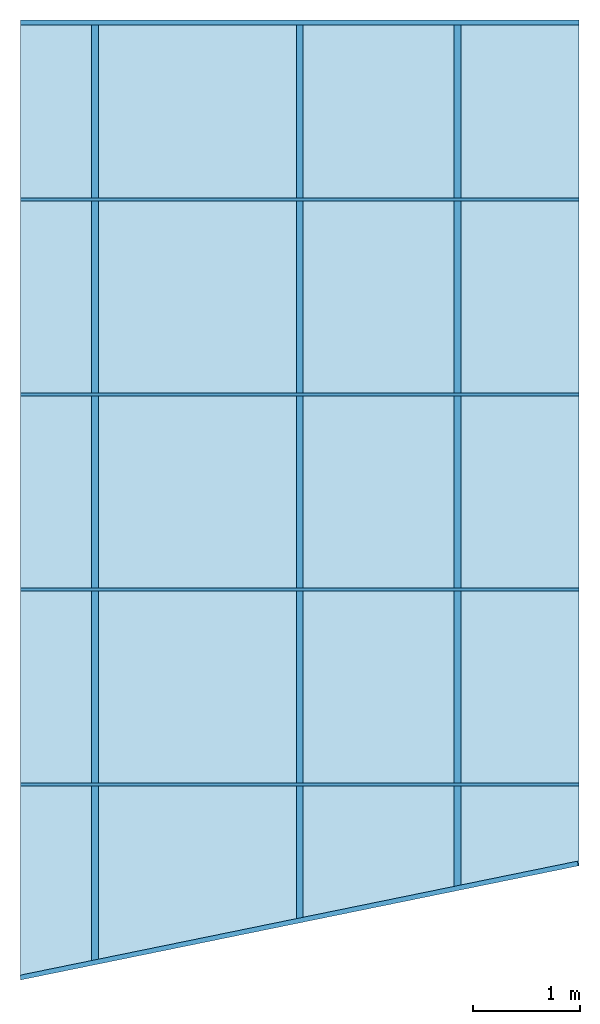
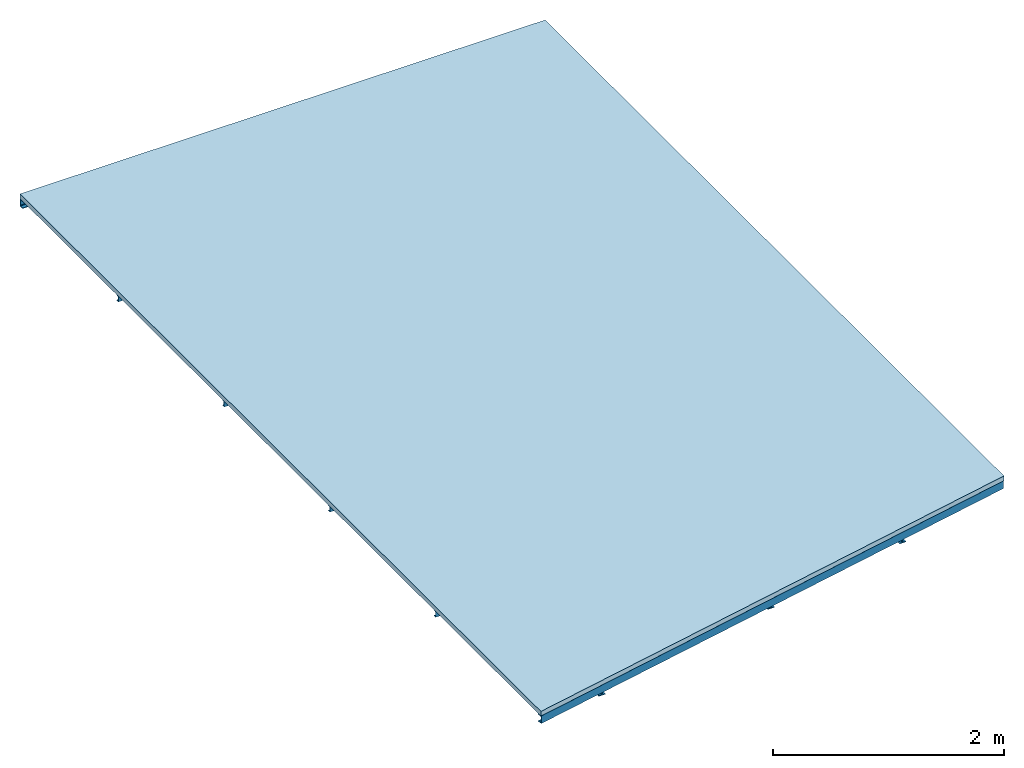
# One storey: 9 beams, 1 slab, 2 elements without a shape of their own.
"""IFC2X3 building model written with IfcOpenShell, lengths in metres."""

from ifc_helpers import new_model, entity, si_unit, converted_unit, derived_unit, direction, frame, frame_2d, origin, place, context, subcontext, project, spatial, polyline, circle_curve, parameter, trimmed, segment, composite_curve, i_section, outline, extrude, material, layer, layer_set, type_object, element, aggregate, save


model = new_model("IFC2X3")

# Units and contexts
model_context = context("Model", 3, precision=1e-05, world=origin(), true_north=direction((6.123233995736766e-17, 1.0)))
body_context = subcontext(model_context, "Body", "Model", "MODEL_VIEW")
ifc_project = project(units=[si_unit("LENGTHUNIT", "METRE"), converted_unit("PLANEANGLEUNIT", "DEGREE", entity("IfcPlaneAngleMeasure", 0.017453292519943278), si_unit("PLANEANGLEUNIT", "RADIAN"), dimensions=[0, 0, 0, 0, 0, 0, 0]), si_unit("AREAUNIT", "SQUARE_METRE"), derived_unit("THERMALTRANSMITTANCEUNIT", [(si_unit("MASSUNIT", "GRAM", prefix="KILO"), 1), (si_unit("THERMODYNAMICTEMPERATUREUNIT", "KELVIN"), -1), (si_unit("TIMEUNIT", "SECOND"), -3)])], contexts=[model_context])

# Site, building, storey
site_placement = place(None, origin())
site = spatial("IfcSite", under=ifc_project, at=site_placement, CompositionType="ELEMENT")
building_placement = place(site_placement, origin())
building = spatial("IfcBuilding", under=site, at=building_placement, CompositionType="ELEMENT")
storey_placement = place(building_placement, frame((0.0, 0.0, 7.0)))
storey = spatial("IfcBuildingStorey", under=building, at=storey_placement, Name="1", CompositionType="ELEMENT", Elevation=6.999999999999999)

# Beams
ifc_material_1 = material(Name="Metal - Steel - 345 MPa")
beam_type_1 = type_object("IfcBeamType", Name="U-Channels:UPN80", PredefinedType="BEAM")
beam_1_placement = place(storey_placement, frame((-0.390396386376727, -3.9843421885533314, 0.0), z_axis=(0.0, 0.0, 1.0), x_axis=(0.9797045907005694, 0.20044678835099888, 0.0)))
element("IfcBeam", 1, at=beam_1_placement, inside=storey, type_object=beam_type_1, material=ifc_material_1, Name="U-Channels:UPN80", ObjectType="U-Channels:UPN80", context=body_context, shape_type="SweptSolid", body=[
    extrude(outline(composite_curve([segment(polyline([(-0.039999999999997406, -0.025113503185145037), (0.04000000000000282, -0.025113503185145037)]), True, "CONTINUOUS"), segment(polyline([(0.040000000000001736, -0.025113503185145037), (0.040000000000001736, 0.019886496814854476)]), True, "CONTINUOUS"), segment(polyline([(0.040000000000001736, 0.019886496814854476), (0.03749277958527237, 0.019886496814854476)]), True, "CONTINUOUS"), segment(trimmed(circle_curve(frame_2d((0.03749277958527237, 0.015886496814854306), x_axis=(0.0, 1.0)), 0.003999999999999967), [parameter(0.0)], [parameter(85.42607874010008)], True, "PARAMETER"), True, "CONTINUOUS"), segment(polyline([(0.03350551847112868, 0.016205477703986036), (0.03126896305773739, -0.011751464963408436)]), True, "CONTINUOUS"), segment(trimmed(circle_curve(frame_2d((0.023294440829447864, -0.01111350318514497), x_axis=(0.9968152785361264, -0.07974522228287521)), 0.007999999999999823), [parameter(274.5739212598999)], [parameter(0.0)], True, "PARAMETER"), False, "CONTINUOUS"), segment(polyline([(0.023294440829447864, -0.01911350318514478), (-0.023294440829452197, -0.01911350318514532)]), True, "CONTINUOUS"), segment(trimmed(circle_curve(frame_2d((-0.023294440829452197, -0.01111350318514443), x_axis=(0.0, -1.0)), 0.008000000000000307), [parameter(274.5739212599038)], [parameter(0.0)], True, "PARAMETER"), False, "CONTINUOUS"), segment(polyline([(-0.03126896305774064, -0.011751464963408436), (-0.03350551847113194, 0.016205477703985494)]), True, "CONTINUOUS"), segment(trimmed(circle_curve(frame_2d((-0.037492779585276706, 0.015886496814854306), x_axis=(0.9968152785361264, 0.07974522228287521)), 0.0039999999999999715), [parameter(0.0)], [parameter(85.42607874010008)], True, "PARAMETER"), True, "CONTINUOUS"), segment(polyline([(-0.037492779585276706, 0.019886496814854476), (-0.039999999999997406, 0.019886496814854476)]), True, "CONTINUOUS"), segment(polyline([(-0.039999999999997406, 0.019886496814854476), (-0.039999999999997406, -0.025113503185145578)]), True, "CONTINUOUS")], self_intersect=False)), frame((0.0012111124129427226, 0.025113503185144496, -0.03999999999999632), z_axis=(1.0, 0.0, 0.0), x_axis=(0.0, 0.0, -1.0)), (0.0, 0.0, 1.0), 5.336763374453148),
])
beam_2_placement = place(storey_placement, frame((-0.3933028648078022, 5.0201700933658255, 0.0)))
element("IfcBeam", 2, at=beam_2_placement, inside=storey, type_object=beam_type_1, material=ifc_material_1, Name="U-Channels:UPN80", ObjectType="U-Channels:UPN80", context=body_context, shape_type="SweptSolid", body=[
    extrude(outline(composite_curve([segment(polyline([(-0.04000000000000282, -0.019886496814854476), (-0.03749277958527345, -0.019886496814854476)]), True, "CONTINUOUS"), segment(trimmed(circle_curve(frame_2d((-0.03749277958527345, -0.015886496814855388), x_axis=(0.0, -1.0)), 0.004000000000000068), [parameter(0.0)], [parameter(85.4260787401048)], True, "PARAMETER"), True, "CONTINUOUS"), segment(polyline([(-0.03350551847112977, -0.016205477703986577), (-0.03126896305773847, 0.011751464963407354)]), True, "CONTINUOUS"), segment(trimmed(circle_curve(frame_2d((-0.02329444082944786, 0.011113503185142806), x_axis=(-0.996815278536112, 0.07974522228305139)), 0.008000000000001296), [parameter(274.5739212599178)], [parameter(0.0)], True, "PARAMETER"), False, "CONTINUOUS"), segment(polyline([(-0.023294440829448943, 0.019113503185144237), (0.02329444082945111, 0.019113503185144237)]), True, "CONTINUOUS"), segment(trimmed(circle_curve(frame_2d((0.02329444082945111, 0.011113503185143888), x_axis=(0.0, 1.0)), 0.008000000000000871), [parameter(274.573921259903)], [parameter(0.0)], True, "PARAMETER"), False, "CONTINUOUS"), segment(polyline([(0.03126896305773955, 0.011751464963407354), (0.03350551847113086, -0.016205477703986577)]), True, "CONTINUOUS"), segment(trimmed(circle_curve(frame_2d((0.03749277958527562, -0.015886496814855388), x_axis=(-0.9968152785361328, -0.07974522228279317)), 0.004000000000000068), [parameter(0.0)], [parameter(85.4260787401048)], True, "PARAMETER"), True, "CONTINUOUS"), segment(polyline([(0.03749277958527562, -0.019886496814854476), (0.03999999999999632, -0.019886496814854476)]), True, "CONTINUOUS"), segment(polyline([(0.03999999999999632, -0.019886496814854476), (0.03999999999999632, 0.025113503185145037)]), True, "CONTINUOUS"), segment(polyline([(0.03999999999999632, 0.025113503185143955), (-0.0400000000000039, 0.025113503185143955)]), True, "CONTINUOUS"), segment(polyline([(-0.04000000000000282, 0.025113503185143955), (-0.04000000000000282, -0.019886496814855565)]), True, "CONTINUOUS")], self_intersect=False)), frame((0.0, -0.025113503185143955, -0.04000000000000823), z_axis=(1.0, 0.0, 0.0), x_axis=(0.0, 0.0, -1.0)), (0.0, 0.0, 1.0), 5.24),
])

# Assembly, beams
assembly_placement = place(storey_placement, origin())
assembly = element("IfcElementAssembly", 3, at=assembly_placement, inside=storey, Name="Structural Beam System:Structural Framing System", ObjectType="Structural Beam System:Structural Framing System", AssemblyPlace="NOTDEFINED", PredefinedType="BEAM_GRID")
beam_type_2 = type_object("IfcBeamType", Name="U-Channels:UPN60", PredefinedType="JOIST")
beam_3_placement = place(assembly_placement, frame((4.846697135192183, -2.1561368517533097, 0.0), z_axis=(0.0, 0.0, 1.0), x_axis=(-1.0, 0.0, 0.0)))
beam_3 = element("IfcBeam", 4, at=beam_3_placement, type_object=beam_type_2, material=ifc_material_1, Name="U-Channels:UPN60", ObjectType="U-Channels:UPN60", context=body_context, shape_type="SweptSolid", body=[
    extrude(outline(composite_curve([segment(polyline([(-0.03000000000000184, -0.012539872611141402), (-0.027969584688953497, -0.012539872611141402)]), True, "CONTINUOUS"), segment(trimmed(circle_curve(frame_2d((-0.027969584688953497, -0.009539872611141541), x_axis=(0.0, -1.0)), 0.002999999999999759), [parameter(0.0)], [parameter(85.42607874010397)], True, "PARAMETER"), True, "CONTINUOUS"), segment(polyline([(-0.02497913885334547, -0.009779108277990205), (-0.023721722293301845, 0.005938598722555085)]), True, "CONTINUOUS"), segment(trimmed(circle_curve(frame_2d((-0.0177408306220847, 0.005460127388856944), x_axis=(-0.9968152785361161, 0.07974522228300297)), 0.006000000000000927), [parameter(274.5739212599176)], [parameter(0.0)], True, "PARAMETER"), False, "CONTINUOUS"), segment(polyline([(-0.01774083062208578, 0.011460127388857745), (0.017740830622089032, 0.011460127388857745)]), True, "CONTINUOUS"), segment(trimmed(circle_curve(frame_2d((0.01774083062208795, 0.005460127388856944), x_axis=(0.0, 1.0)), 0.006000000000000927), [parameter(274.5739212599176)], [parameter(0.0)], True, "PARAMETER"), False, "CONTINUOUS"), segment(polyline([(0.02372172229330618, 0.005938598722555356), (0.0249791388533498, -0.009779108277989935)]), True, "CONTINUOUS"), segment(trimmed(circle_curve(frame_2d((0.027969584688957834, -0.009539872611141541), x_axis=(-0.9968152785361316, -0.0797452222828075)), 0.002999999999999763), [parameter(0.0)], [parameter(85.42607874010397)], True, "PARAMETER"), True, "CONTINUOUS"), segment(polyline([(0.027969584688957834, -0.012539872611141402), (0.029999999999997515, -0.012539872611141402)]), True, "CONTINUOUS"), segment(polyline([(0.029999999999997515, -0.012539872611141402), (0.029999999999997515, 0.017460127388857737)]), True, "CONTINUOUS"), segment(polyline([(0.029999999999997515, 0.017460127388858007), (-0.030000000000002927, 0.017460127388858007)]), True, "CONTINUOUS"), segment(polyline([(-0.03000000000000184, 0.017460127388858007), (-0.03000000000000184, -0.012539872611141131)]), True, "CONTINUOUS")], self_intersect=False)), frame((0.0, -0.008360127388858721, -0.030000000000007257), z_axis=(1.0, 0.0, 0.0), x_axis=(0.0, 0.0, -1.0)), (0.0, 0.0, 1.0), 5.24),
])
beam_4_placement = place(assembly_placement, frame((4.846697135192186, -0.32733685175330945, 0.0), z_axis=(0.0, 0.0, 1.0), x_axis=(-1.0, 0.0, 0.0)))
beam_4 = element("IfcBeam", 5, at=beam_4_placement, type_object=beam_type_2, material=ifc_material_1, Name="U-Channels:UPN60", ObjectType="U-Channels:UPN60", context=body_context, shape_type="SweptSolid", body=[
    extrude(outline(composite_curve([segment(polyline([(-0.03000000000000184, -0.012539872611140994), (-0.027969584688953497, -0.012539872611140994)]), True, "CONTINUOUS"), segment(trimmed(circle_curve(frame_2d((-0.027969584688953497, -0.00953987261114154), x_axis=(0.0, -1.0)), 0.002999999999999397), [parameter(0.0)], [parameter(85.42607874010912)], True, "PARAMETER"), True, "CONTINUOUS"), segment(polyline([(-0.02497913885334547, -0.009779108277989662), (-0.023721722293301845, 0.005938598722555559)]), True, "CONTINUOUS"), segment(trimmed(circle_curve(frame_2d((-0.0177408306220847, 0.005460127388857283), x_axis=(-0.9968152785361152, 0.07974522228301419)), 0.006000000000001057), [parameter(274.5739212599182)], [parameter(0.0)], True, "PARAMETER"), False, "CONTINUOUS"), segment(polyline([(-0.01774083062208578, 0.01146012738885822), (0.017740830622089032, 0.01146012738885822)]), True, "CONTINUOUS"), segment(trimmed(circle_curve(frame_2d((0.01774083062208795, 0.00546012738885735), x_axis=(0.0, 1.0)), 0.006000000000001025), [parameter(274.5739212599182)], [parameter(0.0)], True, "PARAMETER"), False, "CONTINUOUS"), segment(polyline([(0.02372172229330618, 0.005938598722555559), (0.0249791388533498, -0.009779108277989662)]), True, "CONTINUOUS"), segment(trimmed(circle_curve(frame_2d((0.027969584688957834, -0.00953987261114154), x_axis=(-0.9968152785361389, -0.07974522228271785)), 0.0029999999999993864), [parameter(0.0)], [parameter(85.42607874010912)], True, "PARAMETER"), True, "CONTINUOUS"), segment(polyline([(0.027969584688957834, -0.012539872611140994), (0.029999999999997515, -0.012539872611140994)]), True, "CONTINUOUS"), segment(polyline([(0.029999999999997515, -0.012539872611140994), (0.029999999999997515, 0.01746012738885821)]), True, "CONTINUOUS"), segment(polyline([(0.029999999999997515, 0.01746012738885821), (-0.030000000000002927, 0.01746012738885821)]), True, "CONTINUOUS"), segment(polyline([(-0.03000000000000184, 0.01746012738885821), (-0.03000000000000184, -0.012539872611140994)]), True, "CONTINUOUS")], self_intersect=False)), frame((0.0, -0.00836012738885906, -0.030000000000007257), z_axis=(1.0, 0.0, 0.0), x_axis=(0.0, 0.0, -1.0)), (0.0, 0.0, 1.0), 5.24),
])
beam_5_placement = place(assembly_placement, frame((4.846697135192189, 1.5014631482466907, 0.0), z_axis=(0.0, 0.0, 1.0), x_axis=(-1.0, 0.0, 0.0)))
beam_5 = element("IfcBeam", 6, at=beam_5_placement, type_object=beam_type_2, material=ifc_material_1, Name="U-Channels:UPN60", ObjectType="U-Channels:UPN60", context=body_context, shape_type="SweptSolid", body=[
    extrude(outline(composite_curve([segment(polyline([(-0.03000000000000184, -0.012539872611141131), (-0.027969584688953497, -0.012539872611141131)]), True, "CONTINUOUS"), segment(trimmed(circle_curve(frame_2d((-0.027969584688953497, -0.00953987261114127), x_axis=(0.0, -1.0)), 0.002999999999999759), [parameter(0.0)], [parameter(85.42607874010397)], True, "PARAMETER"), True, "CONTINUOUS"), segment(polyline([(-0.02497913885334547, -0.009779108277989935), (-0.023721722293301845, 0.005938598722555356)]), True, "CONTINUOUS"), segment(trimmed(circle_curve(frame_2d((-0.0177408306220847, 0.005460127388857215), x_axis=(-0.9968152785361161, 0.07974522228300297)), 0.006000000000000927), [parameter(274.5739212599176)], [parameter(0.0)], True, "PARAMETER"), False, "CONTINUOUS"), segment(polyline([(-0.01774083062208578, 0.011460127388858016), (0.017740830622089032, 0.011460127388858016)]), True, "CONTINUOUS"), segment(trimmed(circle_curve(frame_2d((0.01774083062208795, 0.005460127388857215), x_axis=(0.0, 1.0)), 0.006000000000000927), [parameter(274.5739212599176)], [parameter(0.0)], True, "PARAMETER"), False, "CONTINUOUS"), segment(polyline([(0.02372172229330618, 0.005938598722555626), (0.0249791388533498, -0.009779108277989664)]), True, "CONTINUOUS"), segment(trimmed(circle_curve(frame_2d((0.027969584688957834, -0.00953987261114127), x_axis=(-0.9968152785361316, -0.0797452222828075)), 0.002999999999999763), [parameter(0.0)], [parameter(85.42607874010397)], True, "PARAMETER"), True, "CONTINUOUS"), segment(polyline([(0.027969584688957834, -0.012539872611141131), (0.029999999999997515, -0.012539872611141131)]), True, "CONTINUOUS"), segment(polyline([(0.029999999999997515, -0.012539872611141131), (0.029999999999997515, 0.017460127388858007)]), True, "CONTINUOUS"), segment(polyline([(0.029999999999997515, 0.017460127388858278), (-0.030000000000002927, 0.017460127388858278)]), True, "CONTINUOUS"), segment(polyline([(-0.03000000000000184, 0.017460127388858278), (-0.03000000000000184, -0.01253987261114086)]), True, "CONTINUOUS")], self_intersect=False)), frame((0.0, -0.008360127388858992, -0.030000000000007257), z_axis=(1.0, 0.0, 0.0), x_axis=(0.0, 0.0, -1.0)), (0.0, 0.0, 1.0), 5.24),
])
beam_6_placement = place(assembly_placement, frame((4.8466971351921915, 3.33026314824669, 0.0), z_axis=(0.0, 0.0, 1.0), x_axis=(-1.0, 0.0, 0.0)))
beam_6 = element("IfcBeam", 7, at=beam_6_placement, type_object=beam_type_2, material=ifc_material_1, Name="U-Channels:UPN60", ObjectType="U-Channels:UPN60", context=body_context, shape_type="SweptSolid", body=[
    extrude(outline(composite_curve([segment(polyline([(-0.03000000000000184, -0.01253987261114086), (-0.027969584688953497, -0.01253987261114086)]), True, "CONTINUOUS"), segment(trimmed(circle_curve(frame_2d((-0.027969584688952415, -0.009539872611142083), x_axis=(0.0, -1.0)), 0.0029999999999985793), [parameter(0.0)], [parameter(85.42607874013846)], True, "PARAMETER"), True, "CONTINUOUS"), segment(polyline([(-0.02497913885334547, -0.009779108277989664), (-0.023721722293301845, 0.005938598722555626)]), True, "CONTINUOUS"), segment(trimmed(circle_curve(frame_2d((-0.0177408306220847, 0.005460127388856673), x_axis=(-0.9968152785361052, 0.07974522228313748)), 0.006000000000001852), [parameter(274.5739212599253)], [parameter(0.0)], True, "PARAMETER"), False, "CONTINUOUS"), segment(polyline([(-0.01774083062208578, 0.011460127388858557), (0.017740830622089032, 0.011460127388858557)]), True, "CONTINUOUS"), segment(trimmed(circle_curve(frame_2d((0.01774083062208795, 0.005460127388856673), x_axis=(0.0, 1.0)), 0.006000000000001859), [parameter(274.5739212599253)], [parameter(0.0)], True, "PARAMETER"), False, "CONTINUOUS"), segment(polyline([(0.02372172229330618, 0.005938598722555626), (0.0249791388533498, -0.009779108277989664)]), True, "CONTINUOUS"), segment(trimmed(circle_curve(frame_2d((0.02796958468895675, -0.009539872611142083), x_axis=(-0.9968152785361509, -0.07974522228256721)), 0.002999999999998575), [parameter(0.0)], [parameter(85.42607874013846)], True, "PARAMETER"), True, "CONTINUOUS"), segment(polyline([(0.027969584688957834, -0.01253987261114086), (0.029999999999997515, -0.01253987261114086)]), True, "CONTINUOUS"), segment(polyline([(0.029999999999997515, -0.01253987261114086), (0.029999999999997515, 0.017460127388858278)]), True, "CONTINUOUS"), segment(polyline([(0.029999999999997515, 0.017460127388858278), (-0.030000000000002927, 0.017460127388858278)]), True, "CONTINUOUS"), segment(polyline([(-0.03000000000000184, 0.017460127388858278), (-0.03000000000000184, -0.01253987261114086)]), True, "CONTINUOUS")], self_intersect=False)), frame((0.0, -0.008360127388859263, -0.030000000000007257), z_axis=(1.0, 0.0, 0.0), x_axis=(0.0, 0.0, -1.0)), (0.0, 0.0, 1.0), 5.24),
])
aggregate(assembly, [beam_3, beam_4, beam_5, beam_6])

# Beams
beam_type_3 = type_object("IfcBeamType", Name="IPE-Beams:IPE120", PredefinedType="BEAM")
beam_7_placement = place(storey_placement, frame((0.27469713519211963, 5.020170093365825, 0.0), z_axis=(0.0, 0.0, 1.0), x_axis=(0.0, -1.0, 0.0)))
element("IfcBeam", 8, at=beam_7_placement, inside=storey, type_object=beam_type_3, material=ifc_material_1, Name="IPE-Beams:IPE120", ObjectType="IPE-Beams:IPE120", context=body_context, shape_type="SweptSolid", body=[
    extrude(outline(composite_curve([segment(polyline([(0.053700000000000796, -0.03199999999999946), (0.05999999999999935, -0.03199999999999946)]), True, "CONTINUOUS"), segment(polyline([(0.05999999999999935, -0.03199999999999939), (0.05999999999999935, 0.03200000000000024)]), True, "CONTINUOUS"), segment(polyline([(0.05999999999999935, 0.03200000000000024), (0.053700000000000796, 0.03200000000000024)]), True, "CONTINUOUS"), segment(polyline([(0.053700000000000796, 0.03200000000000024), (0.053700000000000796, 0.009200000000000139)]), True, "CONTINUOUS"), segment(trimmed(circle_curve(frame_2d((0.04670000000000022, 0.009199999999999195), x_axis=(1.0, 0.0)), 0.00699999999999919), [parameter(269.99999999999324)], [parameter(0.0)], True, "PARAMETER"), False, "CONTINUOUS"), segment(polyline([(0.0467000000000013, 0.002200000000000042), (-0.04669999999999913, 0.0021999999999997716)]), True, "CONTINUOUS"), segment(trimmed(circle_curve(frame_2d((-0.04669999999999913, 0.009199999999998924), x_axis=(0.0, -1.0)), 0.006999999999999176), [parameter(269.99999999999324)], [parameter(0.0)], True, "PARAMETER"), False, "CONTINUOUS"), segment(polyline([(-0.0536999999999997, 0.009199999999999736), (-0.0536999999999997, 0.031999999999999834)]), True, "CONTINUOUS"), segment(polyline([(-0.0536999999999997, 0.031999999999999834), (-0.060000000000000435, 0.031999999999999834)]), True, "CONTINUOUS"), segment(polyline([(-0.060000000000000435, 0.031999999999999834), (-0.060000000000000435, -0.032000000000000375)]), True, "CONTINUOUS"), segment(polyline([(-0.060000000000000435, -0.032000000000000375), (-0.0536999999999997, -0.032000000000000375)]), True, "CONTINUOUS"), segment(polyline([(-0.0536999999999997, -0.03200000000000034), (-0.0536999999999997, -0.009200000000000312)]), True, "CONTINUOUS"), segment(trimmed(circle_curve(frame_2d((-0.04669999999999913, -0.009199999999999469), x_axis=(-1.0, 0.0)), 0.006999999999999179), [parameter(269.9999999999927)], [parameter(0.0)], True, "PARAMETER"), False, "CONTINUOUS"), segment(polyline([(-0.04669999999999913, -0.002200000000000313), (0.0467000000000013, -0.002200000000000011)]), True, "CONTINUOUS"), segment(trimmed(circle_curve(frame_2d((0.04670000000000022, -0.00919999999999906), x_axis=(0.0, 1.0)), 0.006999999999999025), [parameter(269.99999999999244)], [parameter(0.0)], True, "PARAMETER"), False, "CONTINUOUS"), segment(polyline([(0.053700000000000796, -0.00920000000000001), (0.053700000000000796, -0.031999999999999494)]), True, "CONTINUOUS")], self_intersect=False)), frame((0.0002173353762570258, 0.03200000000000512, -0.05999999999999827), z_axis=(1.0, 0.0, 0.0), x_axis=(0.0, 0.0, -1.0)), (0.0, 0.0, 1.0), 8.849),
])
beam_8_placement = place(storey_placement, frame((3.738697135192143, 5.020170093365811, 0.0), z_axis=(0.0, 0.0, 1.0), x_axis=(0.0, -1.0, 0.0)))
element("IfcBeam", 9, at=beam_8_placement, inside=storey, type_object=beam_type_3, material=ifc_material_1, Name="IPE-Beams:IPE120", ObjectType="IPE-Beams:IPE120", context=body_context, shape_type="SweptSolid", body=[
    extrude(i_section(OverallWidth=0.06400000000000007, OverallDepth=0.11999999999999979, WebThickness=0.004400000000000083, FlangeThickness=0.006300000000000734, FilletRadius=0.006999999999999485, at=frame_2d((5.412337245047638e-16, 8.118505867571457e-16), x_axis=(0.0, 1.0))), frame((0.00035149824602419814, -0.03200000000000528, -0.060000000000005854), z_axis=(1.0, 0.0, 0.0), x_axis=(0.0, 0.0, -1.0)), (0.0, 0.0, 1.0), 8.16),
])
beam_9_placement = place(storey_placement, frame((2.226697135192196, 5.020170093365817, 0.0), z_axis=(0.0, 0.0, 1.0), x_axis=(0.0, -1.0, 0.0)))
element("IfcBeam", 10, at=beam_9_placement, inside=storey, type_object=beam_type_3, material=ifc_material_1, Name="IPE-Beams:IPE120", ObjectType="IPE-Beams:IPE120", context=body_context, shape_type="SweptSolid", body=[
    extrude(i_section(OverallWidth=0.06400000000000033, OverallDepth=0.11999999999999979, WebThickness=0.004400000000000083, FlangeThickness=0.006300000000000734, FilletRadius=0.006999999999999106, at=frame_2d((5.412337245047638e-16, -2.706168622523819e-16), x_axis=(0.0, 1.0))), frame((2.8503367527653725e-05, 0.0, -0.060000000000005854), z_axis=(1.0, 0.0, 0.0), x_axis=(0.0, 0.0, -1.0)), (0.0, 0.0, 1.0), 8.447000000000001),
])

# Roof, slab
ifc_material_2 = material(Name="Metal Deck")
ifc_layer = layer(ifc_material_2, 0.05)
ifc_layer_set = layer_set([ifc_layer], Name="Basic Roof")
roof_placement = place(storey_placement, frame((-0.3933028648078174, -3.984936851753293, 0.0)))
roof = element("IfcRoof", 11, at=roof_placement, inside=storey, material=ifc_layer_set, Name="Basic Roof", ObjectType="Basic Roof", ShapeType="NOTDEFINED")
type_product = type_object("IfcTypeProduct", Name="Basic Roof")
slab_placement = place(roof_placement, origin())
slab = element("IfcSlab", 12, at=slab_placement, type_object=type_product, material=ifc_layer_set, Name="Basic Roof", ObjectType="Basic Roof", PredefinedType="ROOF", context=body_context, shape_type="SweptSolid", body=[
    extrude(outline(polyline([(-2.620000000000006, -4.502553472559559), (2.619999999999994, -3.430453595791456), (2.620000000000005, 4.502553472559543), (-2.6199999999999903, 4.502553472559559), (-2.620000000000006, -4.502553472559559)])), frame((2.620000000000006, 4.502553472559559, 0.0)), (0.0, 0.0, 1.0), 0.050000000000000544),
])
aggregate(roof, [slab])

save(model, "model.ifc")
